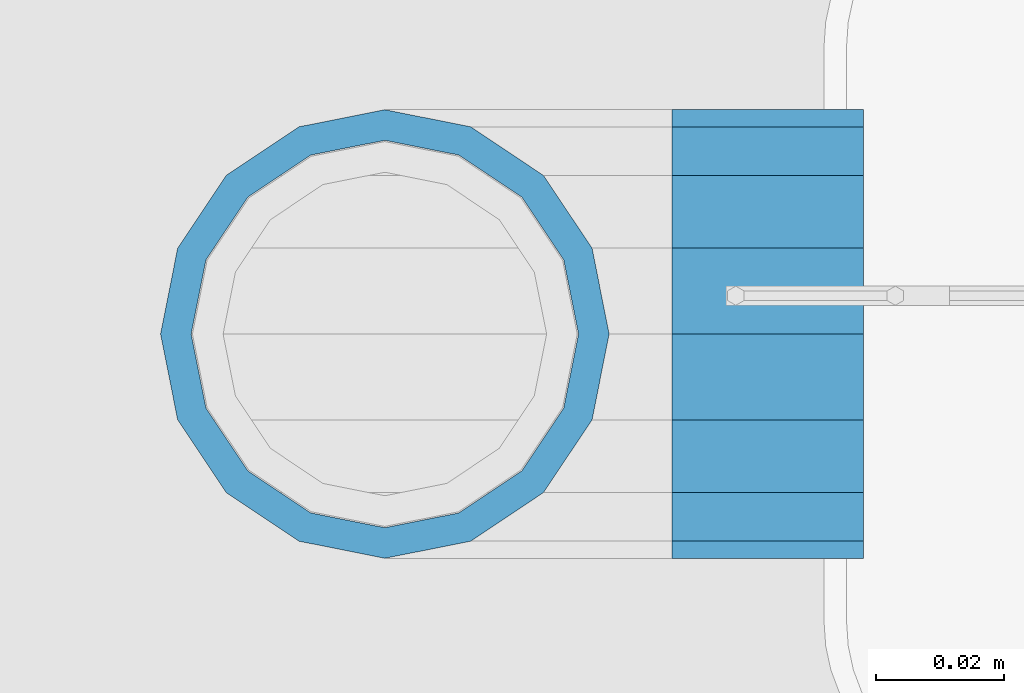
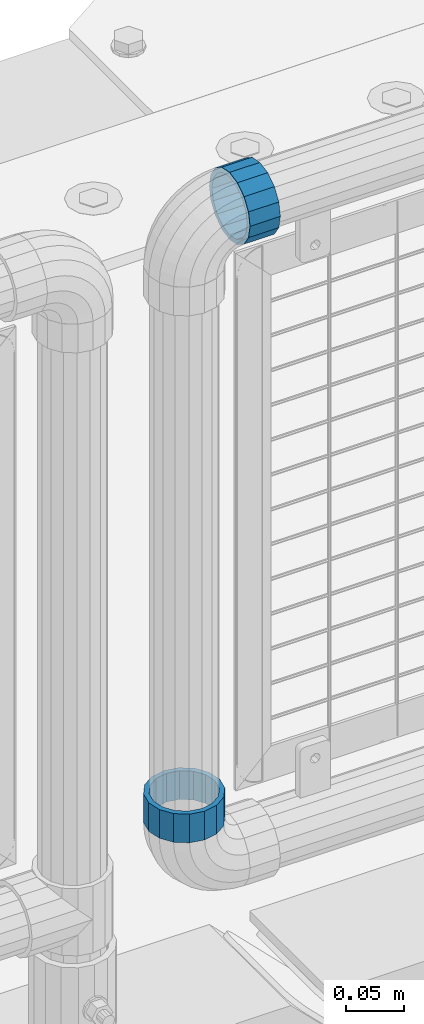
# One storey, part 183 of 270: 2 beams.
"""IFC2X3 building model written with IfcOpenShell, lengths in millimetres."""

import ifcopenshell
import ifcopenshell.guid

model = None  # the IFC model being written
_history = None  # IfcOwnerHistory: only IFC2X3 demands one
_inside = {}  # id of a spatial element -> (the spatial element, [elements in it])
_under = {}  # id of a project, library or spatial element -> (it, [spatial elements below it])
_declared = {}  # id of a project -> (the project, [libraries it declares])
_typed = {}  # id of a type object -> (the type object, [elements of that type])
_made_of = {}  # id of a material, layer set ... -> (it, [elements and type objects made of it])


def new_model(schema):
    """Start an empty IFC model of exactly this schema.

    Asked for "IFC4X3", IfcOpenShell would pick the latest addendum, in which some entities
    have other attributes; the version numbers below select the first issue.
    IFC2X3 requires an IfcOwnerHistory on every rooted entity: one is made here for all.
    """
    global model, _history
    if schema == "IFC4X3":
        model = ifcopenshell.file(schema_version=(4, 3, 0, 0))
    else:
        model = ifcopenshell.file(schema=schema)
    _inside.clear()
    _under.clear()
    _declared.clear()
    _typed.clear()
    _made_of.clear()
    _history = None
    if model.schema == "IFC2X3":
        org = make("IfcOrganization", Name="unknown")
        user = make(
            "IfcPersonAndOrganization",
            ThePerson=make("IfcPerson", FamilyName="unknown"),
            TheOrganization=org,
        )
        app = make(
            "IfcApplication",
            ApplicationDeveloper=org,
            Version="unknown",
            ApplicationFullName="unknown",
            ApplicationIdentifier="unknown",
        )
        _history = make(
            "IfcOwnerHistory",
            OwningUser=user,
            OwningApplication=app,
            ChangeAction="ADDED",
            CreationDate=0,
        )
    return model


def make(cls, **values):
    """One entity of the class cls with the attributes given. An attribute that is None is left unset."""
    return model.create_entity(
        cls, **{name: value for name, value in values.items() if value is not None}
    )


def rooted(cls, **values):
    """An entity with a GlobalId (a new one), such as an element, a storey or a relation."""
    return make(cls, GlobalId=ifcopenshell.guid.new(), OwnerHistory=_history, **values)


def si_unit(unit_type, name, prefix=None):
    """IfcSIUnit, for example si_unit("LENGTHUNIT", "METRE", prefix="MILLI")."""
    return make("IfcSIUnit", UnitType=unit_type, Prefix=prefix, Name=name)


def assignment(units):
    """IfcUnitAssignment: the units of a project."""
    return None if units is None else make("IfcUnitAssignment", Units=units)


def point(xyz):
    """IfcCartesianPoint."""
    return None if xyz is None else make("IfcCartesianPoint", Coordinates=xyz)


def direction(xyz):
    """IfcDirection."""
    return None if xyz is None else make("IfcDirection", DirectionRatios=xyz)


def frame(location, z_axis=None, x_axis=None):
    """IfcAxis2Placement3D, a coordinate frame: its origin and axes. An axis left out is left unset."""
    return make(
        "IfcAxis2Placement3D",
        Location=point(location),
        Axis=direction(z_axis),
        RefDirection=direction(x_axis),
    )


def origin_with_axes():
    """The frame at (0, 0, 0) with the z axis (0, 0, 1) and the x axis (1, 0, 0) written out."""
    return frame((0.0, 0.0, 0.0), z_axis=(0.0, 0.0, 1.0), x_axis=(1.0, 0.0, 0.0))


def place(relative_to, where):
    """IfcLocalPlacement: puts the frame where relative to a parent placement (None: the world)."""
    return make(
        "IfcLocalPlacement", PlacementRelTo=relative_to, RelativePlacement=where
    )


def context(
    kind, dimensions, precision=None, world=None, true_north=None, identifier=None
):
    """IfcGeometricRepresentationContext, for example the 3D "Model" context."""
    return make(
        "IfcGeometricRepresentationContext",
        ContextIdentifier=identifier,
        ContextType=kind,
        CoordinateSpaceDimension=dimensions,
        Precision=precision,
        WorldCoordinateSystem=world,
        TrueNorth=true_north,
    )


def subcontext(parent, identifier, kind, view, scale=None):
    """IfcGeometricRepresentationSubContext, for example "Body" below "Model"."""
    return make(
        "IfcGeometricRepresentationSubContext",
        ContextIdentifier=identifier,
        ContextType=kind,
        ParentContext=parent,
        TargetScale=scale,
        TargetView=view,
    )


def project(units=None, contexts=None):
    """IfcProject with its units and contexts."""
    return rooted(
        "IfcProject",
        Name="project",
        RepresentationContexts=contexts,
        UnitsInContext=assignment(units),
    )


def spatial(cls, under=None, at=None, **own):
    """A site, building, storey or space (cls), placed at a placement, below another one or the project."""
    s = rooted(cls, ObjectPlacement=at, **own)
    if under is not None:
        _under.setdefault(under.id(), (under, []))[1].append(s)
    return s


def faces_of(points, faces, orient=None, outer=None):
    """IfcFace entities. A face is a list of loops; a loop is a list of indices into points, from 0.

    orient and outer hold one flag for each loop. By default every Orientation is true, the
    first loop of a face is its IfcFaceOuterBound and the others are IfcFaceBound.
    """
    made = []
    for i, loops in enumerate(faces):
        bounds = []
        for j, loop in enumerate(loops):
            is_outer = j == 0 if outer is None else outer[i][j]
            bounds.append(
                make(
                    "IfcFaceOuterBound" if is_outer else "IfcFaceBound",
                    Bound=make("IfcPolyLoop", Polygon=[points[k] for k in loop]),
                    Orientation=True if orient is None else orient[i][j],
                )
            )
        made.append(make("IfcFace", Bounds=bounds))
    return made


def faceted_brep(points, faces, orient=None, outer=None, voids=None):
    """IfcFacetedBrep: a solid bounded by flat faces; with voids (closed shells), ...WithVoids."""
    shared = [point(p) for p in points]
    hull = make("IfcClosedShell", CfsFaces=faces_of(shared, faces, orient, outer))
    if voids is None:
        return make("IfcFacetedBrep", Outer=hull)
    return make(
        "IfcFacetedBrepWithVoids",
        Outer=hull,
        Voids=[
            make(cls, CfsFaces=faces_of(shared, fs, o, b)) for cls, fs, o, b in voids
        ],
    )


def shape(context_of_items, identifier, shape_type, items):
    """IfcShapeRepresentation: the items that make up one representation, for example the "Body"."""
    return make(
        "IfcShapeRepresentation",
        ContextOfItems=context_of_items,
        RepresentationIdentifier=identifier,
        RepresentationType=shape_type,
        Items=items,
    )


def material(Name=None, Category=None):
    """IfcMaterial."""
    return make("IfcMaterial", Name=Name, Category=Category)


def made_of(thing, what):
    """Note that an element or type object is made of a material, layer set ...; save() writes the relation."""
    if what is not None:
        _made_of.setdefault(what.id(), (what, []))[1].append(thing)
    return thing


def type_object(cls, material=None, **own):
    """A type object (cls), such as IfcWallType, which elements share."""
    return made_of(rooted(cls, **own), material)


def element(
    cls,
    number,
    at=None,
    inside=None,
    cuts=None,
    type_object=None,
    material=None,
    context=None,
    identifier="Body",
    shape_type=None,
    held_by="IfcProductDefinitionShape",
    body=None,
    shapes=None,
    **own,
):
    """One element of the class cls, such as IfcWall. Its Tag is "e" and its number.

    at: its placement. inside: the storey or other place that contains it. cuts: it is an
    opening in that element (IfcRelVoidsElement). A single representation is given by context,
    identifier, shape_type and body (its items); several are given by shapes. held_by: the class
    of the entity that holds the representations. save() writes the other relations.
    """
    e = rooted(cls, Tag="e%d" % number, ObjectPlacement=at, **own)
    if body is not None:
        shapes = [shape(context, identifier, shape_type, body)]
    if shapes is not None:
        e.Representation = make(held_by, Representations=shapes)
    if inside is not None:
        _inside.setdefault(inside.id(), (inside, []))[1].append(e)
    if cuts is not None:
        rooted(
            "IfcRelVoidsElement", RelatingBuildingElement=cuts, RelatedOpeningElement=e
        )
    if type_object is not None:
        _typed.setdefault(type_object.id(), (type_object, []))[1].append(e)
    return made_of(e, material)


def aggregate(whole, parts):
    """IfcRelAggregates: a whole, such as a stair, and the parts it consists of."""
    return rooted("IfcRelAggregates", RelatingObject=whole, RelatedObjects=parts)


def save(model, path):
    """Write the relations noted so far, then the file.

    IfcRelAggregates (storeys below a building ...), IfcRelContainedInSpatialStructure (elements
    in a storey), IfcRelDefinesByType, IfcRelAssociatesMaterial and IfcRelDeclares: one each for
    every whole, place, type object, material and project.
    """
    for whole, parts in _under.values():
        aggregate(whole, parts)
    for where, things in _inside.values():
        rooted(
            "IfcRelContainedInSpatialStructure",
            RelatedElements=things,
            RelatingStructure=where,
        )
    for kind, things in _typed.values():
        rooted("IfcRelDefinesByType", RelatedObjects=things, RelatingType=kind)
    for what, things in _made_of.values():
        rooted("IfcRelAssociatesMaterial", RelatedObjects=things, RelatingMaterial=what)
    for by, libraries in _declared.values():
        rooted("IfcRelDeclares", RelatingContext=by, RelatedDefinitions=libraries)
    model.write(path)


model = new_model("IFC2X3")

# Units and contexts
model_context = context("Model", 3, precision=1e-05, world=origin_with_axes())
body_context = subcontext(model_context, "Body", "Model", "MODEL_VIEW")
ifc_project = project(units=[si_unit("LENGTHUNIT", "METRE", prefix="MILLI"), si_unit("AREAUNIT", "SQUARE_METRE"), si_unit("VOLUMEUNIT", "CUBIC_METRE"), si_unit("MASSUNIT", "GRAM", prefix="KILO"), si_unit("TIMEUNIT", "SECOND"), si_unit("PLANEANGLEUNIT", "RADIAN"), si_unit("SOLIDANGLEUNIT", "STERADIAN"), si_unit("THERMODYNAMICTEMPERATUREUNIT", "DEGREE_CELSIUS"), si_unit("LUMINOUSINTENSITYUNIT", "LUMEN")], contexts=[model_context])

# Site, building, storey
site_placement = place(None, origin_with_axes())
site = spatial("IfcSite", under=ifc_project, at=site_placement, CompositionType="ELEMENT")
building_placement = place(site_placement, origin_with_axes())
building = spatial("IfcBuilding", under=site, at=building_placement, Name="Standard", CompositionType="ELEMENT")
storey_placement = place(building_placement, origin_with_axes())
storey = spatial("IfcBuildingStorey", under=building, at=storey_placement, Name="Undefined", CompositionType="ELEMENT", Elevation=0.0)

# Beams
ifc_material = material(Name="Misc_Undefined")
beam_type = type_object("IfcBeamType", PredefinedType="NOTDEFINED")
beam_1_placement = place(storey_placement, frame((18694.61, -16335.5, 373.170000000002), z_axis=(-1.0, 0.0, 0.0), x_axis=(0.0, 0.0, -1.0)))
element("IfcBeam", 1, at=beam_1_placement, inside=storey, type_object=beam_type, material=ifc_material, context=body_context, shape_type="Brep", body=[
    faceted_brep([(0.0, -30.3500000000004, 0.0), (0.0, -28.0397438117179, 11.614442172282), (30.0, -28.0397438117179, 11.6144421722805), (30.0, -30.3500000000004, 0.0), (0.0, -21.4606908090118, 21.46069080901), (30.0, -21.4606908090118, 21.4606908090117), (0.0, -11.6144421722802, 28.0397438117179), (30.0, -11.6144421722802, 28.0397438117176), (0.0, 0.0, 30.3499999999985), (30.0, 0.0, 30.35), (0.0, 11.6144421722802, 28.0397438117179), (30.0, 11.6144421722802, 28.0397438117176), (0.0, 21.4606908090118, 21.46069080901), (30.0, 21.4606908090118, 21.4606908090117), (0.0, 28.0397438117179, 11.614442172282), (30.0, 28.0397438117179, 11.6144421722805), (0.0, 30.3500000000004, 0.0), (30.0, 30.3500000000004, 0.0), (0.0, 28.0397438117179, -11.614442172282), (30.0, 28.0397438117179, -11.6144421722805), (0.0, 21.4606908090118, -21.46069080901), (30.0, 21.4606908090118, -21.4606908090117), (0.0, 11.6144421722802, -28.0397438117179), (30.0, 11.6144421722802, -28.0397438117176), (0.0, 0.0, -30.3499999999985), (30.0, 0.0, -30.35), (0.0, -11.6144421722802, -28.0397438117179), (30.0, -11.6144421722802, -28.0397438117176), (0.0, -21.4606908090118, -21.46069080901), (30.0, -21.4606908090118, -21.4606908090117), (0.0, -28.0397438117179, -11.614442172282), (30.0, -28.0397438117179, -11.6144421722805), (0.0, -35.1499999999996, 0.0), (0.0, -32.4743655677721, -13.4513226476338), (30.0, -32.4743655677721, -13.4513226476329), (30.0, -35.1499999999996, 0.0), (0.0, -24.8548033587067, -24.8548033587067), (30.0, -24.8548033587067, -24.8548033587072), (0.0, -13.4513226476338, -32.4743655677703), (30.0, -13.4513226476338, -32.4743655677718), (0.0, 0.0, -35.1499999999996), (30.0, 0.0, -35.15), (0.0, 13.4513226476338, -32.4743655677703), (30.0, 13.4513226476338, -32.4743655677718), (0.0, 24.8548033587067, -24.8548033587067), (30.0, 24.8548033587067, -24.8548033587072), (0.0, 32.4743655677721, -13.4513226476338), (30.0, 32.4743655677721, -13.4513226476329), (0.0, 35.1499999999996, 0.0), (30.0, 35.1499999999996, 0.0), (0.0, 32.4743655677721, 13.4513226476338), (30.0, 32.4743655677721, 13.4513226476329), (0.0, 24.8548033587067, 24.8548033587067), (30.0, 24.8548033587067, 24.8548033587072), (0.0, 13.4513226476338, 32.4743655677703), (30.0, 13.4513226476338, 32.4743655677718), (0.0, 0.0, 35.1499999999996), (30.0, 0.0, 35.15), (0.0, -13.4513226476338, 32.4743655677703), (30.0, -13.4513226476338, 32.4743655677718), (0.0, -24.8548033587067, 24.8548033587067), (30.0, -24.8548033587067, 24.8548033587072), (0.0, -32.4743655677721, 13.4513226476338), (30.0, -32.4743655677721, 13.4513226476329)], [[[0, 1, 2, 3]], [[1, 4, 5, 2]], [[4, 6, 7, 5]], [[6, 8, 9, 7]], [[8, 10, 11, 9]], [[10, 12, 13, 11]], [[12, 14, 15, 13]], [[14, 16, 17, 15]], [[16, 18, 19, 17]], [[18, 20, 21, 19]], [[20, 22, 23, 21]], [[22, 24, 25, 23]], [[24, 26, 27, 25]], [[26, 28, 29, 27]], [[28, 30, 31, 29]], [[30, 0, 3, 31]], [[32, 33, 34, 35]], [[33, 36, 37, 34]], [[36, 38, 39, 37]], [[38, 40, 41, 39]], [[40, 42, 43, 41]], [[42, 44, 45, 43]], [[44, 46, 47, 45]], [[46, 48, 49, 47]], [[48, 50, 51, 49]], [[50, 52, 53, 51]], [[52, 54, 55, 53]], [[54, 56, 57, 55]], [[56, 58, 59, 57]], [[58, 60, 61, 59]], [[60, 62, 63, 61]], [[62, 32, 35, 63]], [[37, 39, 41, 43, 45, 47, 49, 51, 53, 55, 57, 59, 61, 63, 35, 34], [5, 7, 9, 11, 13, 15, 17, 19, 21, 23, 25, 27, 29, 31, 3, 2]], [[62, 60, 58, 56, 54, 52, 50, 48, 46, 44, 42, 40, 38, 36, 33, 32], [30, 28, 26, 24, 22, 20, 18, 16, 14, 12, 10, 8, 6, 4, 1, 0]]]),
])
beam_2_placement = place(storey_placement, frame((18739.61, -16335.5, 969.849999999999), z_axis=(0.0, 0.0, 1.0), x_axis=(1.0, 0.0, 0.0)))
element("IfcBeam", 2, at=beam_2_placement, inside=storey, type_object=beam_type, material=ifc_material, context=body_context, shape_type="Brep", body=[
    faceted_brep([(0.0, -30.3500000000004, 0.0), (0.0, -28.0397438117179, 11.614442172282), (30.0, -28.0397438117179, 11.6144421722805), (30.0, -30.3500000000004, 0.0), (0.0, -21.4606908090118, 21.46069080901), (30.0, -21.4606908090118, 21.4606908090117), (0.0, -11.6144421722802, 28.0397438117179), (30.0, -11.6144421722802, 28.0397438117176), (0.0, 0.0, 30.3499999999985), (30.0, 0.0, 30.35), (0.0, 11.6144421722802, 28.0397438117179), (30.0, 11.6144421722802, 28.0397438117176), (0.0, 21.4606908090118, 21.46069080901), (30.0, 21.4606908090118, 21.4606908090117), (0.0, 28.0397438117179, 11.614442172282), (30.0, 28.0397438117179, 11.6144421722805), (0.0, 30.3500000000004, 0.0), (30.0, 30.3500000000004, 0.0), (0.0, 28.0397438117179, -11.614442172282), (30.0, 28.0397438117179, -11.6144421722805), (0.0, 21.4606908090118, -21.46069080901), (30.0, 21.4606908090118, -21.4606908090117), (0.0, 11.6144421722802, -28.0397438117179), (30.0, 11.6144421722802, -28.0397438117176), (0.0, 0.0, -30.3499999999985), (30.0, 0.0, -30.35), (0.0, -11.6144421722802, -28.0397438117179), (30.0, -11.6144421722802, -28.0397438117176), (0.0, -21.4606908090118, -21.46069080901), (30.0, -21.4606908090118, -21.4606908090117), (0.0, -28.0397438117179, -11.614442172282), (30.0, -28.0397438117179, -11.6144421722805), (0.0, -35.1499999999996, 0.0), (0.0, -32.4743655677721, -13.4513226476338), (30.0, -32.4743655677721, -13.4513226476329), (30.0, -35.1499999999996, 0.0), (0.0, -24.8548033587067, -24.8548033587067), (30.0, -24.8548033587067, -24.8548033587072), (0.0, -13.4513226476338, -32.4743655677703), (30.0, -13.4513226476338, -32.4743655677718), (0.0, 0.0, -35.1499999999996), (30.0, 0.0, -35.15), (0.0, 13.4513226476338, -32.4743655677703), (30.0, 13.4513226476338, -32.4743655677718), (0.0, 24.8548033587067, -24.8548033587067), (30.0, 24.8548033587067, -24.8548033587072), (0.0, 32.4743655677721, -13.4513226476338), (30.0, 32.4743655677721, -13.4513226476329), (0.0, 35.1499999999996, 0.0), (30.0, 35.1499999999996, 0.0), (0.0, 32.4743655677721, 13.4513226476338), (30.0, 32.4743655677721, 13.4513226476329), (0.0, 24.8548033587067, 24.8548033587067), (30.0, 24.8548033587067, 24.8548033587072), (0.0, 13.4513226476338, 32.4743655677703), (30.0, 13.4513226476338, 32.4743655677718), (0.0, 0.0, 35.1499999999996), (30.0, 0.0, 35.15), (0.0, -13.4513226476338, 32.4743655677703), (30.0, -13.4513226476338, 32.4743655677718), (0.0, -24.8548033587067, 24.8548033587067), (30.0, -24.8548033587067, 24.8548033587072), (0.0, -32.4743655677721, 13.4513226476338), (30.0, -32.4743655677721, 13.4513226476329)], [[[0, 1, 2, 3]], [[1, 4, 5, 2]], [[4, 6, 7, 5]], [[6, 8, 9, 7]], [[8, 10, 11, 9]], [[10, 12, 13, 11]], [[12, 14, 15, 13]], [[14, 16, 17, 15]], [[16, 18, 19, 17]], [[18, 20, 21, 19]], [[20, 22, 23, 21]], [[22, 24, 25, 23]], [[24, 26, 27, 25]], [[26, 28, 29, 27]], [[28, 30, 31, 29]], [[30, 0, 3, 31]], [[32, 33, 34, 35]], [[33, 36, 37, 34]], [[36, 38, 39, 37]], [[38, 40, 41, 39]], [[40, 42, 43, 41]], [[42, 44, 45, 43]], [[44, 46, 47, 45]], [[46, 48, 49, 47]], [[48, 50, 51, 49]], [[50, 52, 53, 51]], [[52, 54, 55, 53]], [[54, 56, 57, 55]], [[56, 58, 59, 57]], [[58, 60, 61, 59]], [[60, 62, 63, 61]], [[62, 32, 35, 63]], [[37, 39, 41, 43, 45, 47, 49, 51, 53, 55, 57, 59, 61, 63, 35, 34], [5, 7, 9, 11, 13, 15, 17, 19, 21, 23, 25, 27, 29, 31, 3, 2]], [[62, 60, 58, 56, 54, 52, 50, 48, 46, 44, 42, 40, 38, 36, 33, 32], [30, 28, 26, 24, 22, 20, 18, 16, 14, 12, 10, 8, 6, 4, 1, 0]]]),
])

save(model, "model.ifc")
